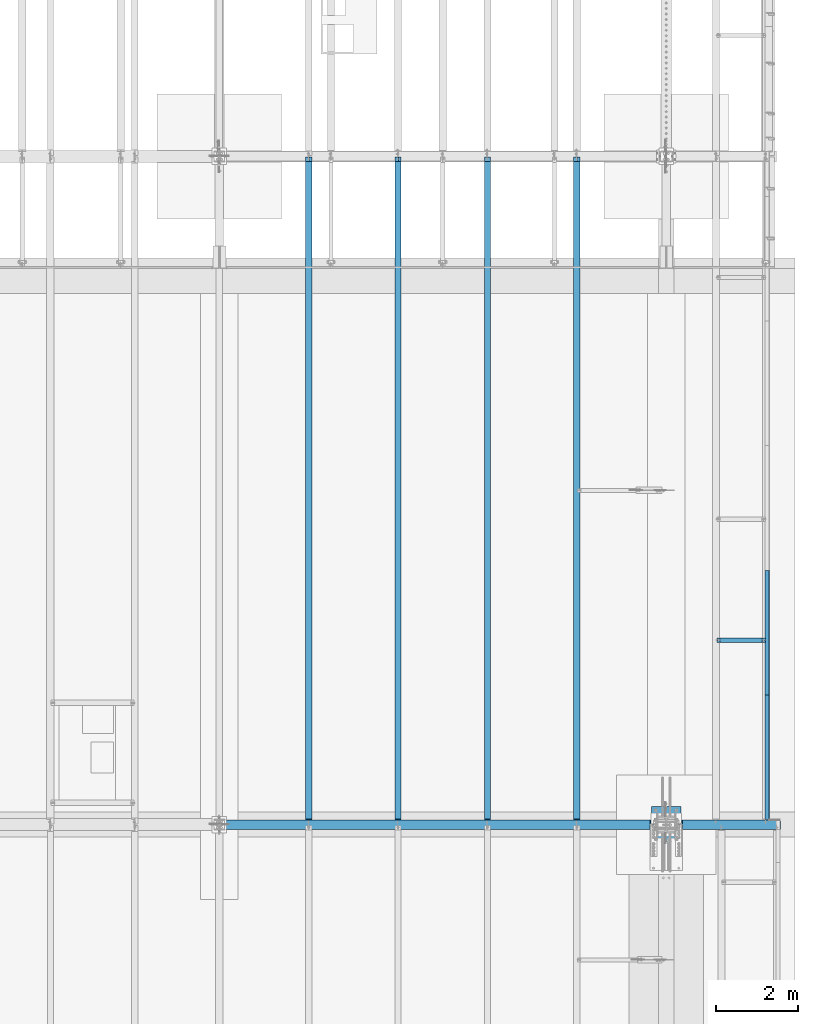
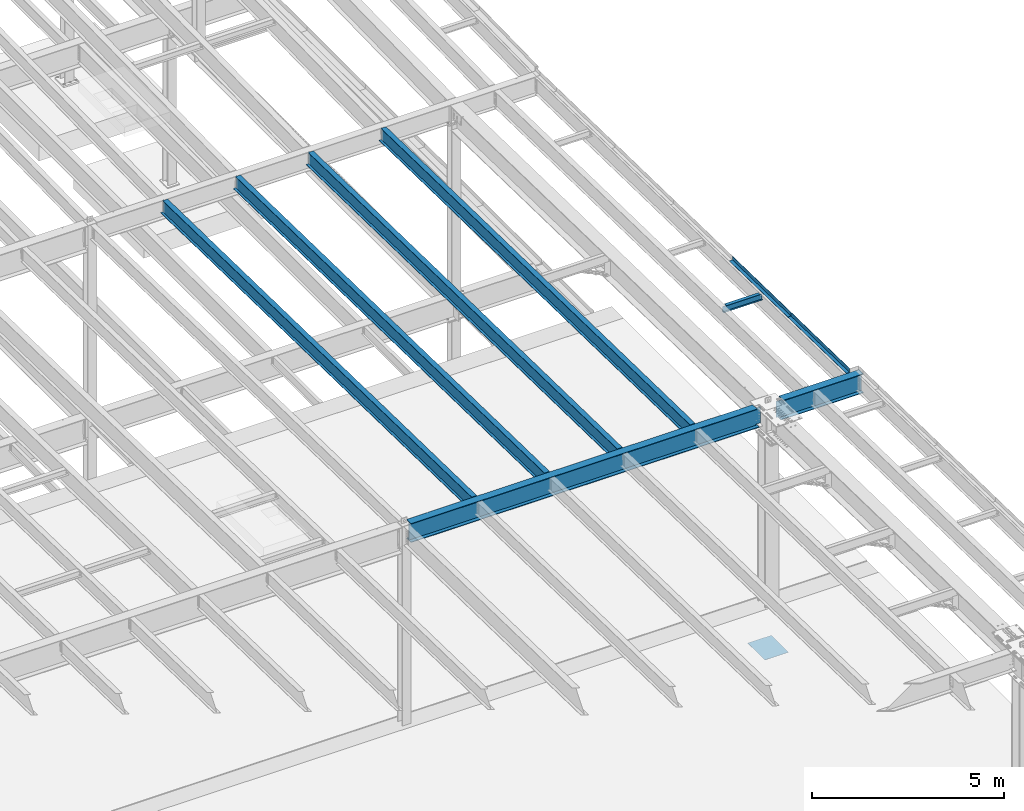
# One storey, part 1117 of 1763: 10 beams, 9 elements without a shape of their own.
"""IFC2X3 building model written with IfcOpenShell, lengths in millimetres."""

from ifc_helpers import new_model, si_unit, frame, origin_with_axes, place, context, subcontext, project, spatial, faceted_brep, material, type_object, element, aggregate, save


model = new_model("IFC2X3")

# Units and contexts
model_context = context("Model", 3, precision=1e-05, world=origin_with_axes())
body_context = subcontext(model_context, "Body", "Model", "MODEL_VIEW")
ifc_project = project(units=[si_unit("LENGTHUNIT", "METRE", prefix="MILLI"), si_unit("AREAUNIT", "SQUARE_METRE"), si_unit("VOLUMEUNIT", "CUBIC_METRE"), si_unit("MASSUNIT", "GRAM", prefix="KILO"), si_unit("TIMEUNIT", "SECOND"), si_unit("PLANEANGLEUNIT", "RADIAN"), si_unit("SOLIDANGLEUNIT", "STERADIAN"), si_unit("THERMODYNAMICTEMPERATUREUNIT", "DEGREE_CELSIUS"), si_unit("LUMINOUSINTENSITYUNIT", "LUMEN")], contexts=[model_context])

# Site, building, storey
site_placement = place(None, origin_with_axes())
site = spatial("IfcSite", under=ifc_project, at=site_placement, CompositionType="ELEMENT")
building_placement = place(site_placement, origin_with_axes())
building = spatial("IfcBuilding", under=site, at=building_placement, Name="Undefined", CompositionType="ELEMENT")
storey_placement = place(building_placement, origin_with_axes())
storey = spatial("IfcBuildingStorey", under=building, at=storey_placement, Name="Undefined", CompositionType="ELEMENT", Elevation=0.0)

# Assembly, beams
assembly_1_placement = place(storey_placement, origin_with_axes())
assembly_1 = element("IfcElementAssembly", 1, at=assembly_1_placement, inside=storey, Name="BEAM", AssemblyPlace="NOTDEFINED", PredefinedType="RIGID_FRAME")
ifc_material_1 = material(Name="STEEL/A36")
beam_type_1 = type_object("IfcBeamType", PredefinedType="NOTDEFINED")
beam_1_placement = place(assembly_1_placement, frame((-21608.4906443556, 15334.9692637605, 11600.5383642867), z_axis=(0.0, -0.999781542838788, 0.0209013539966307), x_axis=(1.0, 0.0, 0.0)))
beam_1 = element("IfcBeam", 2, at=beam_1_placement, type_object=beam_type_1, material=ifc_material_1, Name="BENT_PLATE", context=body_context, shape_type="Brep", body=[
    faceted_brep([(0.0, -3.17499999999927, -1523.99999999999), (0.0, -3.17499999999927, 1524.0), (0.0, 3.17499999999927, 1524.0), (0.0, 3.17499999999927, -1523.99999999999), (95.2499984741262, 3.17499999910251, 1523.99999999978), (95.2499984741262, 3.17500000090149, -1523.99999999977), (101.599998474125, -3.17499999909887, -1523.99999999978), (101.599999809252, -3.17500000000655, 1524.0), (95.2499984741262, 123.825003587437, 1523.99999999985), (95.2499984741262, 123.825003589236, -1523.9999999997), (101.599998474125, 123.825003587437, 1523.99999999985), (101.599998474125, 123.825003589236, -1523.9999999997)], [[[0, 1, 2, 3]], [[3, 2, 4, 5]], [[1, 0, 6, 7]], [[5, 4, 8, 9]], [[4, 2, 1, 7, 10, 8]], [[7, 6, 11, 10]], [[6, 0, 3, 5, 9, 11]], [[10, 11, 9, 8]]]),
])
beam_2_placement = place(assembly_1_placement, frame((-21608.4906443556, 18382.3034061417, 11536.8310281668), z_axis=(0.0, -0.999781542838788, 0.0209013539966307), x_axis=(1.0, 0.0, 0.0)))
beam_2 = element("IfcBeam", 3, at=beam_2_placement, type_object=beam_type_1, material=ifc_material_1, Name="BENT_PLATE", context=body_context, shape_type="Brep", body=[
    faceted_brep([(0.0, -3.17499999999927, -1523.99999999999), (0.0, -3.17499999999927, 1524.0), (0.0, 3.17499999999927, 1524.0), (0.0, 3.17499999999927, -1523.99999999999), (95.2499984741262, 3.17499999910251, 1523.99999999978), (95.2499984741262, 3.17500000090149, -1523.99999999977), (101.599998474125, -3.17499999909887, -1523.99999999978), (101.599999809252, -3.17500000000655, 1524.0), (95.2499984741262, 123.825003587437, 1523.99999999985), (95.2499984741262, 123.825003589236, -1523.9999999997), (101.599998474125, 123.825003587437, 1523.99999999985), (101.599998474125, 123.825003589236, -1523.9999999997)], [[[0, 1, 2, 3]], [[3, 2, 4, 5]], [[1, 0, 6, 7]], [[5, 4, 8, 9]], [[4, 2, 1, 7, 10, 8]], [[7, 6, 11, 10]], [[6, 0, 3, 5, 9, 11]], [[10, 11, 9, 8]]]),
])
aggregate(assembly_1, [beam_1, beam_2])

# Assembly, beam
assembly_2_placement = place(storey_placement, origin_with_axes())
assembly_2 = element("IfcElementAssembly", 4, at=assembly_2_placement, inside=storey, Name="BEAM", AssemblyPlace="NOTDEFINED", PredefinedType="RIGID_FRAME")
ifc_material_2 = material(Name="STEEL/A992")
beam_type_2 = type_object("IfcBeamType", Name="W8X10", PredefinedType="NOTDEFINED")
beam_3_placement = place(assembly_2_placement, frame((-22808.6484080275, 18196.5621887807, 11437.5259261932), z_axis=(0.0, 0.0, 1.0), x_axis=(1.0, 0.0, 0.0)))
beam_3 = element("IfcBeam", 5, at=beam_3_placement, type_object=beam_type_2, material=ifc_material_2, Name="BEAM", ObjectType="W8X10", context=body_context, shape_type="Brep", body=[
    faceted_brep([(1119.19526367187, -50.7999999999993, 100.012500000001), (1119.19526367187, -50.7999999999993, 95.25), (1119.19526367187, -2.38124999999854, 95.25), (1119.19526367187, -2.38124999999854, 83.877501483119), (1119.19526367187, 2.38124999999854, 83.877501483119), (1119.19526367187, 2.38124999999854, 95.25), (1119.19526367187, 50.7999999999993, 95.25), (1119.19526367187, 50.7999999999993, 100.012500000001), (1120.16199359446, -2.38124999999854, 79.0174219650726), (1120.16199359446, 2.38124999999854, 79.0174219650726), (1122.91500749494, -2.38124999999854, 74.8972454969189), (1122.91500749494, 2.38124999999854, 74.8972454969189), (1127.03518396309, -2.38124999999854, 72.1442315964414), (1127.03518396309, 2.38124999999854, 72.1442315964414), (1131.89526348114, -2.38124999999854, 71.1775016738538), (1131.89526348114, 2.38124999999854, 71.1775016738538), (1201.74526367187, -2.38124999999854, 71.1775016738538), (1201.74526367187, 2.38124999999854, 71.1775016738538), (100.012500000012, -50.7999999999993, 100.012500000001), (100.012500000012, 50.7999999999993, 100.012500000001), (100.012500000012, 50.7999999999993, 95.25), (100.012500000012, 2.38124999999854, 95.25), (100.012500000012, 2.38124999999854, 83.877501483119), (100.012500000012, -2.38124999999854, 83.877501483119), (100.012500000012, -2.38124999999854, 95.25), (100.012500000012, -50.7999999999993, 95.25), (99.0457700774241, 2.38124999999854, 79.0174219650726), (99.0457700774241, -2.38124999999854, 79.0174219650726), (96.2927561769466, 2.38124999999854, 74.8972454969189), (96.2927561769466, -2.38124999999854, 74.8972454969189), (92.1725797087929, 2.38124999999854, 72.1442315964414), (92.1725797087929, -2.38124999999854, 72.1442315964414), (87.3125001907465, 2.38124999999854, 71.1775016738538), (87.3125001907465, -2.38124999999854, 71.1775016738538), (17.4625000000015, 2.38124999999854, 71.1775016738538), (17.4625000000015, -2.38124999999854, 71.1775016738538), (17.462499935149, 2.38124999999854, -95.25), (17.4625000000015, 50.7999999999993, -95.25), (17.4625000000015, 50.7999999999993, -100.012500000001), (17.4624996160601, -50.8000000000029, -100.012500000001), (17.4624996160601, -50.8000000000029, -95.25), (17.4624999065727, -2.38124999999854, -95.25), (1201.74526367187, 2.38124999999854, -95.25), (1201.74526367187, 50.7999999999993, -95.25), (1201.74526367187, 50.7999999999993, -100.012500000001), (1201.74526367187, -50.7999999999993, -100.012500000001), (1201.74526367187, -50.7999999999993, -95.25), (1201.74526367187, -2.38124999999854, -95.25)], [[[0, 1, 2, 3, 4, 5, 6, 7]], [[8, 9, 4, 3]], [[10, 11, 9, 8]], [[12, 13, 11, 10]], [[14, 15, 13, 12]], [[16, 17, 15, 14]], [[18, 19, 20, 21, 22, 23, 24, 25]], [[23, 22, 26, 27]], [[27, 26, 28, 29]], [[29, 28, 30, 31]], [[31, 30, 32, 33]], [[33, 32, 34, 35]], [[36, 37, 38, 39, 40, 41, 35, 34]], [[37, 36, 42, 43]], [[38, 37, 43, 44]], [[39, 38, 44, 45]], [[40, 39, 45, 46]], [[41, 40, 46, 47]], [[12, 10, 8, 3, 2, 24, 23, 27, 29, 31, 33, 35, 41, 47, 16, 14]], [[25, 24, 2, 1]], [[18, 25, 1, 0]], [[19, 18, 0, 7]], [[20, 19, 7, 6]], [[21, 20, 6, 5]], [[42, 36, 34, 32, 30, 28, 26, 22, 21, 5, 4, 9, 11, 13, 15, 17]], [[47, 46, 45, 44, 43, 42, 17, 16]]]),
])
aggregate(assembly_2, [beam_3])

assembly_3_placement = place(storey_placement, origin_with_axes())
assembly_3 = element("IfcElementAssembly", 6, at=assembly_3_placement, inside=storey, Name="BEAM", AssemblyPlace="NOTDEFINED", PredefinedType="RIGID_FRAME")
beam_type_3 = type_object("IfcBeamType", Name="W18X40", PredefinedType="NOTDEFINED")
beam_4_placement = place(assembly_3_placement, frame((-26212.2372736984, 13685.8551306872, 11404.7768219843), z_axis=(0.0, 0.0209013539966291, 0.999781542838788), x_axis=(0.0, 0.999781542776098, -0.0209013569953182)))
beam_4 = element("IfcBeam", 7, at=beam_4_placement, type_object=beam_type_3, material=ifc_material_2, Name="BEAM", ObjectType="W18X40", context=body_context, shape_type="Brep", body=[
    faceted_brep([(124.606145118472, -3.96875, 188.652501678604), (124.606145118472, 3.96875, 188.652501678604), (19.0621902453023, 3.96875, 188.652501678604), (19.0621902453023, -3.96875, 188.652501678604), (129.466224636518, -3.96875, 189.619231601191), (129.466224636518, 3.96875, 189.619231601191), (133.586401104671, -3.96875, 192.372245501674), (133.586401104671, 3.96875, 192.372245501674), (136.339415005148, -3.96875, 196.492421969837), (136.339415005148, 3.96875, 196.492421969837), (137.306144927733, -3.96875, 201.352501487894), (137.306144927733, 3.96875, 201.352501487894), (137.306144927707, -76.2000000000007, 227.012500000135), (137.306144927707, 76.2000000000007, 227.012500000135), (137.306144927707, 76.2000000000007, 214.312500000124), (137.306144927707, 3.96875, 214.312500000124), (137.306144927707, -3.96875, 214.312500000124), (137.306144927707, -76.2000000000007, 214.312500000124), (27.4865455604509, -3.96875, -214.31250000018), (27.4865455604509, -76.2000000000007, -214.31250000018), (16326.7347346695, -76.2000000000007, -214.312499990354), (16326.7347346695, -3.96875, -214.312499990354), (27.7520507831297, -76.2000000000007, -227.012500000192), (16327.0002399049, -76.2000000000007, -227.012499990351), (27.7520507831297, 76.2000000000007, -227.012500000192), (16327.0002399049, 76.2000000000007, -227.012499990351), (27.4865455604509, 76.2000000000007, -214.31250000018), (16326.7347346695, 76.2000000000007, -214.312499990354), (27.4865455604509, 3.96875, -214.31250000018), (16326.7347346695, 3.96875, -214.312499990354), (16318.3103789486, 3.96875, 188.652501822573), (16318.3103789486, -3.96875, 188.652501822573), (16220.6543336233, 3.96875, 188.652501822515), (16220.6543336233, -3.96875, 188.652501822515), (16215.7942541052, 3.96875, 189.619231745097), (16215.7942541052, -3.96875, 189.619231745097), (16211.6740776371, 3.96875, 192.372245645573), (16211.6740776371, -3.96875, 192.372245645573), (16208.9210637366, 3.96875, 196.492422113723), (16208.9210637366, -3.96875, 196.492422113723), (16207.954333814, 3.96875, 201.352501631765), (16207.954333814, -3.96875, 201.352501631765), (16207.954333814, -76.2000000000007, 227.01250000951), (16207.954333814, -76.2000000000007, 214.312500009511), (16207.954333814, -3.96875, 214.312500009511), (16207.954333814, 3.96875, 214.312500009511), (16207.954333814, 76.2000000000007, 214.312500009511), (16207.954333814, 76.2000000000007, 227.01250000951)], [[[0, 1, 2, 3]], [[4, 5, 1, 0]], [[6, 7, 5, 4]], [[8, 9, 7, 6]], [[10, 11, 9, 8]], [[12, 13, 14, 15, 11, 10, 16, 17]], [[18, 19, 20, 21]], [[19, 22, 23, 20]], [[22, 24, 25, 23]], [[24, 26, 27, 25]], [[26, 28, 29, 27]], [[21, 20, 23, 25, 27, 29, 30, 31]], [[31, 30, 32, 33]], [[33, 32, 34, 35]], [[35, 34, 36, 37]], [[37, 36, 38, 39]], [[39, 38, 40, 41]], [[42, 43, 44, 41, 40, 45, 46, 47]], [[43, 42, 12, 17]], [[44, 43, 17, 16]], [[8, 6, 4, 0, 3, 18, 21, 31, 33, 35, 37, 39, 41, 44, 16, 10]], [[28, 26, 24, 22, 19, 18, 3, 2]], [[45, 40, 38, 36, 34, 32, 30, 29, 28, 2, 1, 5, 7, 9, 11, 15]], [[46, 45, 15, 14]], [[47, 46, 14, 13]], [[42, 47, 13, 12]]]),
])
aggregate(assembly_3, [beam_4])

assembly_4_placement = place(storey_placement, origin_with_axes())
assembly_4 = element("IfcElementAssembly", 8, at=assembly_4_placement, inside=storey, Name="BEAM", AssemblyPlace="NOTDEFINED", PredefinedType="RIGID_FRAME")
beam_5_placement = place(assembly_4_placement, frame((-28396.6372736984, 13685.8551306872, 11404.7768219843), z_axis=(0.0, 0.0209013539966291, 0.999781542838788), x_axis=(0.0, 0.999781542776098, -0.0209013569953182)))
beam_5 = element("IfcBeam", 9, at=beam_5_placement, type_object=beam_type_3, material=ifc_material_2, Name="BEAM", ObjectType="W18X40", context=body_context, shape_type="Brep", body=[
    faceted_brep([(124.606145118472, -3.96875, 188.652501678604), (124.606145118472, 3.96875, 188.652501678604), (19.0621902453023, 3.96875, 188.652501678604), (19.0621902453023, -3.96875, 188.652501678604), (129.466224636518, -3.96875, 189.619231601191), (129.466224636518, 3.96875, 189.619231601191), (133.586401104671, -3.96875, 192.372245501674), (133.586401104671, 3.96875, 192.372245501674), (136.339415005148, -3.96875, 196.492421969837), (136.339415005148, 3.96875, 196.492421969837), (137.306144927733, -3.96875, 201.352501487894), (137.306144927733, 3.96875, 201.352501487894), (137.306144927707, -76.2000000000007, 227.012500000135), (137.306144927707, 76.2000000000007, 227.012500000135), (137.306144927707, 76.2000000000007, 214.312500000124), (137.306144927707, 3.96875, 214.312500000124), (137.306144927707, -3.96875, 214.312500000124), (137.306144927707, -76.2000000000007, 214.312500000124), (27.4865455604509, -3.96875, -214.31250000018), (27.4865455604509, -76.2000000000007, -214.31250000018), (16326.7347346695, -76.2000000000007, -214.312499990354), (16326.7347346695, -3.96875, -214.312499990354), (27.7520507831297, -76.2000000000007, -227.012500000192), (16327.0002399049, -76.2000000000007, -227.012499990351), (27.7520507831297, 76.2000000000007, -227.012500000192), (16327.0002399049, 76.2000000000007, -227.012499990351), (27.4865455604509, 76.2000000000007, -214.31250000018), (16326.7347346695, 76.2000000000007, -214.312499990354), (27.4865455604509, 3.96875, -214.31250000018), (16326.7347346695, 3.96875, -214.312499990354), (16318.3103789486, 3.96875, 188.652501822573), (16318.3103789486, -3.96875, 188.652501822573), (16220.6543336233, 3.96875, 188.652501822515), (16220.6543336233, -3.96875, 188.652501822515), (16215.7942541052, 3.96875, 189.619231745097), (16215.7942541052, -3.96875, 189.619231745097), (16211.6740776371, 3.96875, 192.372245645573), (16211.6740776371, -3.96875, 192.372245645573), (16208.9210637366, 3.96875, 196.492422113723), (16208.9210637366, -3.96875, 196.492422113723), (16207.954333814, 3.96875, 201.352501631765), (16207.954333814, -3.96875, 201.352501631765), (16207.954333814, -76.2000000000007, 227.01250000951), (16207.954333814, -76.2000000000007, 214.312500009511), (16207.954333814, -3.96875, 214.312500009511), (16207.954333814, 3.96875, 214.312500009511), (16207.954333814, 76.2000000000007, 214.312500009511), (16207.954333814, 76.2000000000007, 227.01250000951)], [[[0, 1, 2, 3]], [[4, 5, 1, 0]], [[6, 7, 5, 4]], [[8, 9, 7, 6]], [[10, 11, 9, 8]], [[12, 13, 14, 15, 11, 10, 16, 17]], [[18, 19, 20, 21]], [[19, 22, 23, 20]], [[22, 24, 25, 23]], [[24, 26, 27, 25]], [[26, 28, 29, 27]], [[21, 20, 23, 25, 27, 29, 30, 31]], [[31, 30, 32, 33]], [[33, 32, 34, 35]], [[35, 34, 36, 37]], [[37, 36, 38, 39]], [[39, 38, 40, 41]], [[42, 43, 44, 41, 40, 45, 46, 47]], [[43, 42, 12, 17]], [[44, 43, 17, 16]], [[8, 6, 4, 0, 3, 18, 21, 31, 33, 35, 37, 39, 41, 44, 16, 10]], [[28, 26, 24, 22, 19, 18, 3, 2]], [[45, 40, 38, 36, 34, 32, 30, 29, 28, 2, 1, 5, 7, 9, 11, 15]], [[46, 45, 15, 14]], [[47, 46, 14, 13]], [[42, 47, 13, 12]]]),
])
aggregate(assembly_4, [beam_5])

assembly_5_placement = place(storey_placement, origin_with_axes())
assembly_5 = element("IfcElementAssembly", 10, at=assembly_5_placement, inside=storey, Name="BEAM", AssemblyPlace="NOTDEFINED", PredefinedType="RIGID_FRAME")
beam_6_placement = place(assembly_5_placement, frame((-30581.0372736984, 13685.8551306872, 11404.7768219843), z_axis=(0.0, 0.0209013539966291, 0.999781542838788), x_axis=(0.0, 0.999781542776098, -0.0209013569953182)))
beam_6 = element("IfcBeam", 11, at=beam_6_placement, type_object=beam_type_3, material=ifc_material_2, Name="BEAM", ObjectType="W18X40", context=body_context, shape_type="Brep", body=[
    faceted_brep([(124.606145118472, -3.96875, 188.652501678604), (124.606145118472, 3.96875, 188.652501678604), (19.0621902453023, 3.96875, 188.652501678604), (19.0621902453023, -3.96875, 188.652501678604), (129.466224636518, -3.96875, 189.619231601191), (129.466224636518, 3.96875, 189.619231601191), (133.586401104671, -3.96875, 192.372245501674), (133.586401104671, 3.96875, 192.372245501674), (136.339415005148, -3.96875, 196.492421969837), (136.339415005148, 3.96875, 196.492421969837), (137.306144927733, -3.96875, 201.352501487894), (137.306144927733, 3.96875, 201.352501487894), (137.306144927707, -76.2000000000007, 227.012500000135), (137.306144927707, 76.2000000000007, 227.012500000135), (137.306144927707, 76.2000000000007, 214.312500000124), (137.306144927707, 3.96875, 214.312500000124), (137.306144927707, -3.96875, 214.312500000124), (137.306144927707, -76.2000000000007, 214.312500000124), (27.4865455604509, -3.96875, -214.31250000018), (27.4865455604509, -76.2000000000007, -214.31250000018), (16326.7347346695, -76.2000000000007, -214.312499990354), (16326.7347346695, -3.96875, -214.312499990354), (27.7520507831297, -76.2000000000007, -227.012500000192), (16327.0002399049, -76.2000000000007, -227.012499990351), (27.7520507831297, 76.2000000000007, -227.012500000192), (16327.0002399049, 76.2000000000007, -227.012499990351), (27.4865455604509, 76.2000000000007, -214.31250000018), (16326.7347346695, 76.2000000000007, -214.312499990354), (27.4865455604509, 3.96875, -214.31250000018), (16326.7347346695, 3.96875, -214.312499990354), (16318.3103789486, 3.96875, 188.652501822573), (16318.3103789486, -3.96875, 188.652501822573), (16220.6543336233, 3.96875, 188.652501822515), (16220.6543336233, -3.96875, 188.652501822515), (16215.7942541052, 3.96875, 189.619231745097), (16215.7942541052, -3.96875, 189.619231745097), (16211.6740776371, 3.96875, 192.372245645573), (16211.6740776371, -3.96875, 192.372245645573), (16208.9210637366, 3.96875, 196.492422113723), (16208.9210637366, -3.96875, 196.492422113723), (16207.954333814, 3.96875, 201.352501631765), (16207.954333814, -3.96875, 201.352501631765), (16207.954333814, -76.2000000000007, 227.01250000951), (16207.954333814, -76.2000000000007, 214.312500009511), (16207.954333814, -3.96875, 214.312500009511), (16207.954333814, 3.96875, 214.312500009511), (16207.954333814, 76.2000000000007, 214.312500009511), (16207.954333814, 76.2000000000007, 227.01250000951)], [[[0, 1, 2, 3]], [[4, 5, 1, 0]], [[6, 7, 5, 4]], [[8, 9, 7, 6]], [[10, 11, 9, 8]], [[12, 13, 14, 15, 11, 10, 16, 17]], [[18, 19, 20, 21]], [[19, 22, 23, 20]], [[22, 24, 25, 23]], [[24, 26, 27, 25]], [[26, 28, 29, 27]], [[21, 20, 23, 25, 27, 29, 30, 31]], [[31, 30, 32, 33]], [[33, 32, 34, 35]], [[35, 34, 36, 37]], [[37, 36, 38, 39]], [[39, 38, 40, 41]], [[42, 43, 44, 41, 40, 45, 46, 47]], [[43, 42, 12, 17]], [[44, 43, 17, 16]], [[8, 6, 4, 0, 3, 18, 21, 31, 33, 35, 37, 39, 41, 44, 16, 10]], [[28, 26, 24, 22, 19, 18, 3, 2]], [[45, 40, 38, 36, 34, 32, 30, 29, 28, 2, 1, 5, 7, 9, 11, 15]], [[46, 45, 15, 14]], [[47, 46, 14, 13]], [[42, 47, 13, 12]]]),
])
aggregate(assembly_5, [beam_6])

assembly_6_placement = place(storey_placement, origin_with_axes())
assembly_6 = element("IfcElementAssembly", 12, at=assembly_6_placement, inside=storey, Name="BEAM", AssemblyPlace="NOTDEFINED", PredefinedType="RIGID_FRAME")
beam_7_placement = place(assembly_6_placement, frame((-32765.4372736984, 13685.8551306872, 11404.7768219843), z_axis=(0.0, 0.0209013539966291, 0.999781542838788), x_axis=(0.0, 0.999781542776098, -0.0209013569953182)))
beam_7 = element("IfcBeam", 13, at=beam_7_placement, type_object=beam_type_3, material=ifc_material_2, Name="BEAM", ObjectType="W18X40", context=body_context, shape_type="Brep", body=[
    faceted_brep([(124.606145118472, -3.96875, 188.652501678604), (124.606145118472, 3.96875, 188.652501678604), (19.0621902453023, 3.96875, 188.652501678604), (19.0621902453023, -3.96875, 188.652501678604), (129.466224636518, -3.96875, 189.619231601191), (129.466224636518, 3.96875, 189.619231601191), (133.586401104671, -3.96875, 192.372245501674), (133.586401104671, 3.96875, 192.372245501674), (136.339415005148, -3.96875, 196.492421969837), (136.339415005148, 3.96875, 196.492421969837), (137.306144927733, -3.96875, 201.352501487894), (137.306144927733, 3.96875, 201.352501487894), (137.306144927707, -76.2000000000007, 227.012500000135), (137.306144927707, 76.2000000000007, 227.012500000135), (137.306144927707, 76.2000000000007, 214.312500000124), (137.306144927707, 3.96875, 214.312500000124), (137.306144927707, -3.96875, 214.312500000124), (137.306144927707, -76.2000000000007, 214.312500000124), (27.4865455604509, -3.96875, -214.31250000018), (27.4865455604509, -76.2000000000007, -214.31250000018), (16326.7347346695, -76.2000000000007, -214.312499990354), (16326.7347346695, -3.96875, -214.312499990354), (27.7520507831297, -76.2000000000007, -227.012500000192), (16327.0002399049, -76.2000000000007, -227.012499990351), (27.7520507831297, 76.2000000000007, -227.012500000192), (16327.0002399049, 76.2000000000007, -227.012499990351), (27.4865455604509, 76.2000000000007, -214.31250000018), (16326.7347346695, 76.2000000000007, -214.312499990354), (27.4865455604509, 3.96875, -214.31250000018), (16326.7347346695, 3.96875, -214.312499990354), (16318.3103789486, 3.96875, 188.652501822573), (16318.3103789486, -3.96875, 188.652501822573), (16220.6543336233, 3.96875, 188.652501822515), (16220.6543336233, -3.96875, 188.652501822515), (16215.7942541052, 3.96875, 189.619231745097), (16215.7942541052, -3.96875, 189.619231745097), (16211.6740776371, 3.96875, 192.372245645573), (16211.6740776371, -3.96875, 192.372245645573), (16208.9210637366, 3.96875, 196.492422113723), (16208.9210637366, -3.96875, 196.492422113723), (16207.954333814, 3.96875, 201.352501631765), (16207.954333814, -3.96875, 201.352501631765), (16207.954333814, -76.2000000000007, 227.01250000951), (16207.954333814, -76.2000000000007, 214.312500009511), (16207.954333814, -3.96875, 214.312500009511), (16207.954333814, 3.96875, 214.312500009511), (16207.954333814, 76.2000000000007, 214.312500009511), (16207.954333814, 76.2000000000007, 227.01250000951)], [[[0, 1, 2, 3]], [[4, 5, 1, 0]], [[6, 7, 5, 4]], [[8, 9, 7, 6]], [[10, 11, 9, 8]], [[12, 13, 14, 15, 11, 10, 16, 17]], [[18, 19, 20, 21]], [[19, 22, 23, 20]], [[22, 24, 25, 23]], [[24, 26, 27, 25]], [[26, 28, 29, 27]], [[21, 20, 23, 25, 27, 29, 30, 31]], [[31, 30, 32, 33]], [[33, 32, 34, 35]], [[35, 34, 36, 37]], [[37, 36, 38, 39]], [[39, 38, 40, 41]], [[42, 43, 44, 41, 40, 45, 46, 47]], [[43, 42, 12, 17]], [[44, 43, 17, 16]], [[8, 6, 4, 0, 3, 18, 21, 31, 33, 35, 37, 39, 41, 44, 16, 10]], [[28, 26, 24, 22, 19, 18, 3, 2]], [[45, 40, 38, 36, 34, 32, 30, 29, 28, 2, 1, 5, 7, 9, 11, 15]], [[46, 45, 15, 14]], [[47, 46, 14, 13]], [[42, 47, 13, 12]]]),
])
aggregate(assembly_6, [beam_7])

assembly_7_placement = place(storey_placement, origin_with_axes())
assembly_7 = element("IfcElementAssembly", 14, at=assembly_7_placement, inside=storey, Name="BEAM", AssemblyPlace="NOTDEFINED", PredefinedType="RIGID_FRAME")
beam_type_4 = type_object("IfcBeamType", Name="W24X76", PredefinedType="NOTDEFINED")
beam_8_placement = place(assembly_7_placement, frame((-24027.8372736984, 13690.599999996, 11328.5272294638), z_axis=(0.0, 0.0, 1.0), x_axis=(1.0, 0.0, 0.0)))
beam_8 = element("IfcBeam", 15, at=beam_8_placement, type_object=beam_type_4, material=ifc_material_2, Name="BEAM", ObjectType="W24X76", context=body_context, shape_type="Brep", body=[
    faceted_brep([(397.431593813748, -114.299999999999, 303.2125), (397.431593813748, 114.299999999999, 303.2125), (387.349979961135, 114.299999999999, 285.75), (387.349979961135, 5.55624999999964, 285.75), (387.120779916699, 5.55624999999964, 285.352999496459), (387.120779916699, -5.55624999999964, 285.352999496459), (387.349979961135, -5.55624999999964, 285.75), (387.349979961135, -114.299999999999, 285.75), (414.338007039743, -5.55624999999964, 285.352999496459), (414.338007039743, 5.55624999999964, 285.352999496459), (434.089161356696, 5.55624999999964, 275.165223063012), (434.089161356696, -5.55624999999964, 275.165223063012), (437.785210853959, 5.55624999999964, 271.771708296024), (437.785210853959, -5.55624999999964, 271.771708296024), (439.243893030496, 5.55624999999964, 266.970773942399), (439.243893030496, -5.55624999999964, 266.970773942399), (438.060417706809, 5.55624999999964, 262.094698623232), (438.060417706809, -5.55624999999964, 262.094698623232), (434.563204052207, 5.55624999999964, 258.496612880223), (434.563204052207, -5.55624999999964, 258.496612880223), (429.722742942478, 5.55624999999964, 257.174999999999), (429.722742942478, -5.55624999999964, 257.174999999999), (238.125000447901, 5.55624999999964, 257.174999999999), (238.125000447901, -5.55624999999964, 257.174999999999), (238.125004048354, 5.55624999999964, -257.174999999999), (238.125004048354, -5.55624999999964, -257.174999999999), (365.649739712866, 5.55624999999964, -257.174999999999), (365.649739712866, -5.55624999999964, -257.174999999999), (370.49020086927, 5.55624999999964, -258.496612907766), (370.49020086927, -5.55624999999964, -258.496612907766), (373.987414529602, 5.55624999999964, -262.094698718112), (373.987414529602, -5.55624999999964, -262.094698718112), (375.17088979626, 5.55624999999964, -266.970774104921), (375.17088979626, -5.55624999999964, -266.970774104921), (373.712207508914, 5.55624999999964, -271.771708479522), (373.712207508914, -5.55624999999964, -271.771708479522), (370.016157886253, 5.55624999999964, -275.165223187232), (370.016157886253, -5.55624999999964, -275.165223187232), (350.265002430922, 5.55624999999964, -285.352999496459), (350.265002430922, -5.55624999999964, -285.352999496459), (330.985811230083, 5.55624999999964, -285.352999496459), (330.985811230083, -5.55624999999964, -285.352999496459), (2793.99999999999, 5.55624999999964, -285.75), (2793.99999999999, 114.299999999999, -285.75), (330.756619772179, 114.299999999999, -285.75), (330.756619772179, 5.55624999999964, -285.75), (2793.99999999999, 114.299999999999, -303.2125), (2793.99999999999, -114.299999999999, -303.2125), (320.675383607617, -114.299999999999, -303.2125), (320.675383607617, 114.299999999999, -303.2125), (2793.99999999999, -114.299999999999, -285.75), (330.756619772179, -114.299999999999, -285.75), (2793.99999999999, -5.55624999999964, -285.75), (330.756619772179, -5.55624999999964, -285.75), (2793.99999999999, 5.55624999999964, 285.75), (2793.99999999999, 114.299999999999, 285.75), (2793.99999999999, 114.299999999999, 303.2125), (2793.99999999999, -114.299999999999, 303.2125), (2793.99999999999, -114.299999999999, 285.75), (2793.99999999999, -5.55624999999964, 285.75)], [[[0, 1, 2, 3, 4, 5, 6, 7]], [[8, 9, 10, 11]], [[11, 10, 12, 13]], [[13, 12, 14, 15]], [[15, 14, 16, 17]], [[17, 16, 18, 19]], [[19, 18, 20, 21]], [[21, 20, 22, 23]], [[24, 25, 23, 22]], [[25, 24, 26, 27]], [[27, 26, 28, 29]], [[29, 28, 30, 31]], [[31, 30, 32, 33]], [[33, 32, 34, 35]], [[35, 34, 36, 37]], [[37, 36, 38, 39]], [[39, 38, 40, 41]], [[42, 43, 44, 45]], [[46, 47, 48, 49]], [[47, 50, 51, 48]], [[50, 52, 53, 51]], [[41, 40, 45, 44, 49, 48, 51, 53]], [[43, 46, 49, 44]], [[42, 54, 55, 56, 57, 58, 59, 52, 50, 47, 46, 43]], [[58, 57, 0, 7]], [[59, 58, 7, 6]], [[8, 11, 13, 15, 17, 19, 21, 23, 25, 27, 29, 31, 33, 35, 37, 39, 41, 53, 52, 59, 6, 5]], [[9, 8, 5, 4]], [[54, 42, 45, 40, 38, 36, 34, 32, 30, 28, 26, 24, 22, 20, 18, 16, 14, 12, 10, 9, 4, 3]], [[55, 54, 3, 2]], [[56, 55, 2, 1]], [[57, 56, 1, 0]]]),
])
aggregate(assembly_7, [beam_8])

assembly_8_placement = place(storey_placement, origin_with_axes())
assembly_8 = element("IfcElementAssembly", 16, at=assembly_8_placement, inside=storey, Name="BEAM", AssemblyPlace="NOTDEFINED", PredefinedType="RIGID_FRAME")
beam_9_placement = place(assembly_8_placement, frame((-34949.8372736984, 13690.599999996, 11328.5272294638), z_axis=(0.0, 0.0, 1.0), x_axis=(1.0, 0.0, 0.0)))
beam_9 = element("IfcBeam", 17, at=beam_9_placement, type_object=beam_type_4, material=ifc_material_2, Name="BEAM", ObjectType="W24X76", context=body_context, shape_type="Brep", body=[
    faceted_brep([(10534.6500205235, -114.299999999999, 285.75), (10534.6500205235, -5.55624999999964, 285.75), (10534.8792205791, -5.55624999999964, 285.352999496459), (10534.8792205791, 5.55624999999964, 285.352999496459), (10534.6500205235, 5.55624999999964, 285.75), (10534.6500205235, 114.299999999999, 285.75), (10524.5684061817, 114.299999999999, 303.2125), (10524.5684061817, -114.299999999999, 303.2125), (139.699999999997, 114.299999999999, -285.75), (139.699999999997, 5.55624999999964, -285.75), (10591.2433887396, 5.55624999999964, -285.75), (10591.2433887396, 114.299999999999, -285.75), (10487.9108395391, -5.55624999999964, 275.165223063012), (10487.9108395391, 5.55624999999964, 275.165223063012), (10507.6619938561, 5.55624999999964, 285.352999496459), (10507.6619938561, -5.55624999999964, 285.352999496459), (10484.2147900419, -5.55624999999964, 271.771708296024), (10484.2147900419, 5.55624999999964, 271.771708296024), (10482.7561078653, -5.55624999999964, 266.970773942399), (10482.7561078653, 5.55624999999964, 266.970773942399), (10483.939583189, -5.55624999999964, 262.094698623232), (10483.939583189, 5.55624999999964, 262.094698623232), (10487.4367968436, -5.55624999999964, 258.496612880223), (10487.4367968436, 5.55624999999964, 258.496612880223), (10492.2772579534, -5.55624999999964, 257.174999999999), (10492.2772579534, 5.55624999999964, 257.174999999999), (10683.8750004479, -5.55624999999964, 257.174999999999), (10683.8750004479, 5.55624999999964, 257.174999999999), (10683.8750040483, -5.55624999999964, -257.174999999999), (10683.8750040483, 5.55624999999964, -257.174999999999), (10556.3502683838, -5.55624999999964, -257.174999999999), (10556.3502683838, 5.55624999999964, -257.174999999999), (10551.5098072274, -5.55624999999964, -258.496612907766), (10551.5098072274, 5.55624999999964, -258.496612907766), (10548.0125935671, -5.55624999999964, -262.094698718112), (10548.0125935671, 5.55624999999964, -262.094698718112), (10546.8291183004, -5.55624999999964, -266.970774104921), (10546.8291183004, 5.55624999999964, -266.970774104921), (10548.2878005878, -5.55624999999964, -271.771708479522), (10548.2878005878, 5.55624999999964, -271.771708479522), (10551.9838502104, -5.55624999999964, -275.165223187232), (10551.9838502104, 5.55624999999964, -275.165223187232), (10571.7350056658, -5.55624999999964, -285.352999496459), (10571.7350056658, 5.55624999999964, -285.352999496459), (10591.0141972686, -5.55624999999964, -285.352999496459), (10591.0141972686, 5.55624999999964, -285.352999496459), (139.699999999997, -114.299999999999, -303.2125), (139.699999999997, 114.299999999999, -303.2125), (10601.3246254793, 114.299999999999, -303.2125), (10601.3246254793, -114.299999999999, -303.2125), (139.699999999997, -114.299999999999, -285.75), (10591.2433887396, -114.299999999999, -285.75), (139.699999999997, -5.55624999999964, -285.75), (10591.2433887396, -5.55624999999964, -285.75), (139.699999999997, -5.55624999999964, 285.75), (139.699999999997, -114.299999999999, 285.75), (139.699999999997, -114.299999999999, 303.2125), (139.699999999997, 114.299999999999, 303.2125), (139.699999999997, 114.299999999999, 285.75), (139.699999999997, 5.55624999999964, 285.75)], [[[0, 1, 2, 3, 4, 5, 6, 7]], [[8, 9, 10, 11]], [[12, 13, 14, 15]], [[16, 17, 13, 12]], [[18, 19, 17, 16]], [[20, 21, 19, 18]], [[22, 23, 21, 20]], [[24, 25, 23, 22]], [[26, 27, 25, 24]], [[28, 29, 27, 26]], [[28, 30, 31, 29]], [[32, 33, 31, 30]], [[34, 35, 33, 32]], [[36, 37, 35, 34]], [[38, 39, 37, 36]], [[40, 41, 39, 38]], [[42, 43, 41, 40]], [[43, 42, 44, 45]], [[46, 47, 48, 49]], [[50, 46, 49, 51]], [[52, 50, 51, 53]], [[49, 48, 11, 10, 45, 44, 53, 51]], [[47, 8, 11, 48]], [[46, 50, 52, 54, 55, 56, 57, 58, 59, 9, 8, 47]], [[56, 55, 0, 7]], [[57, 56, 7, 6]], [[58, 57, 6, 5]], [[59, 58, 5, 4]], [[14, 13, 17, 19, 21, 23, 25, 27, 29, 31, 33, 35, 37, 39, 41, 43, 45, 10, 9, 59, 4, 3]], [[15, 14, 3, 2]], [[54, 52, 53, 44, 42, 40, 38, 36, 34, 32, 30, 28, 26, 24, 22, 20, 18, 16, 12, 15, 2, 1]], [[55, 54, 1, 0]]]),
])
aggregate(assembly_8, [beam_9])

assembly_9_placement = place(storey_placement, origin_with_axes())
assembly_9 = element("IfcElementAssembly", 18, at=assembly_9_placement, inside=storey, Name="TEMPLATE", AssemblyPlace="NOTDEFINED", PredefinedType="RIGID_FRAME")
beam_type_5 = type_object("IfcBeamType", PredefinedType="NOTDEFINED")
beam_10_placement = place(assembly_9_placement, frame((-24027.8372736984, 13246.0999999999, 3851.275), z_axis=(-1.0, 0.0, 0.0), x_axis=(0.0, 1.0, 0.0)))
beam_10 = element("IfcBeam", 19, at=beam_10_placement, type_object=beam_type_5, material=ifc_material_1, Name="TEMPLATE", context=body_context, shape_type="Brep", body=[
    faceted_brep([(0.0, 3.17500000000018, -355.599999999999), (0.0, 3.17500000000018, 355.599999999999), (889.0, 3.17500000000018, 355.599999999999), (889.0, 3.17500000000018, -355.599999999999), (0.0, -3.17500000000018, 355.599999999999), (889.0, -3.17500000000018, 355.599999999999), (0.0, -3.17500000000018, -355.599999999999), (889.0, -3.17500000000018, -355.599999999999)], [[[0, 1, 2, 3]], [[1, 4, 5, 2]], [[4, 6, 7, 5]], [[6, 0, 3, 7]], [[5, 7, 3, 2]], [[6, 4, 1, 0]]]),
])
aggregate(assembly_9, [beam_10])

save(model, "model.ifc")
